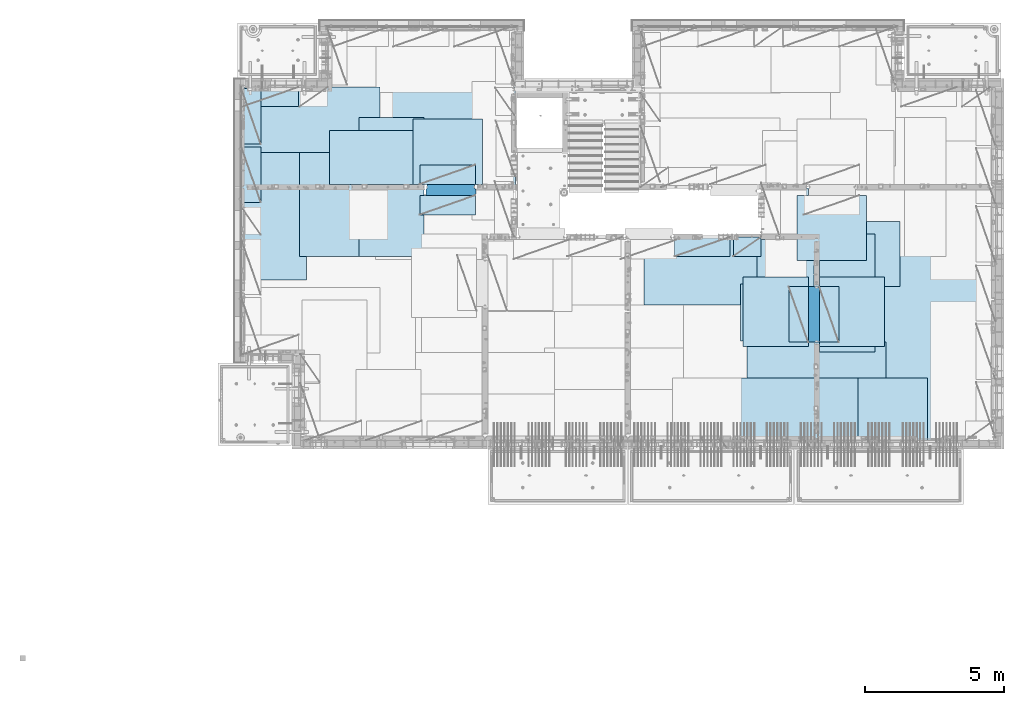
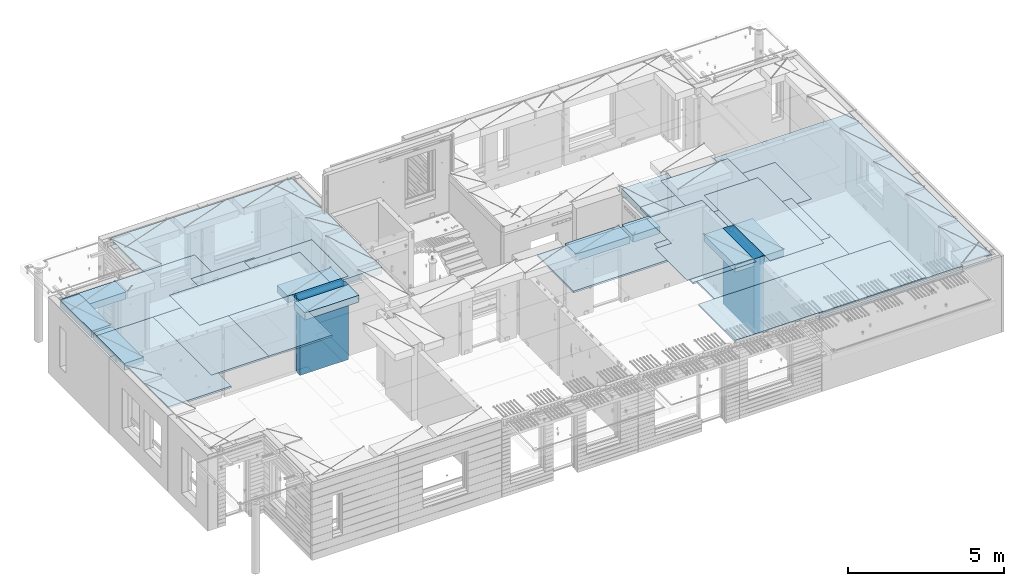
# One storey, part 198 of 341: 27 plates, 2 slabs, 25 elements without a shape of their own.
"""IFC2X3 building model written with IfcOpenShell, lengths in millimetres."""

from ifc_helpers import new_model, si_unit, frame, origin_with_axes, place, context, subcontext, project, spatial, faceted_brep, material, type_object, element, aggregate, save


model = new_model("IFC2X3")

# Units and contexts
model_context = context("Model", 3, precision=1e-05, world=origin_with_axes())
body_context = subcontext(model_context, "Body", "Model", "MODEL_VIEW")
ifc_project = project(units=[si_unit("LENGTHUNIT", "METRE", prefix="MILLI"), si_unit("AREAUNIT", "SQUARE_METRE"), si_unit("VOLUMEUNIT", "CUBIC_METRE"), si_unit("MASSUNIT", "GRAM", prefix="KILO"), si_unit("TIMEUNIT", "SECOND"), si_unit("PLANEANGLEUNIT", "RADIAN"), si_unit("SOLIDANGLEUNIT", "STERADIAN"), si_unit("THERMODYNAMICTEMPERATUREUNIT", "DEGREE_CELSIUS"), si_unit("LUMINOUSINTENSITYUNIT", "LUMEN")], contexts=[model_context])

# Site, building, storey
site_placement = place(None, origin_with_axes())
site = spatial("IfcSite", under=ifc_project, at=site_placement, CompositionType="ELEMENT")
building_placement = place(site_placement, origin_with_axes())
building = spatial("IfcBuilding", under=site, at=building_placement, CompositionType="ELEMENT")
storey_placement = place(building_placement, origin_with_axes())
storey = spatial("IfcBuildingStorey", under=building, at=storey_placement, Name="5", CompositionType="ELEMENT", Elevation=0.0)

# Assembly, slabs
assembly_1_placement = place(storey_placement, origin_with_axes())
assembly_1 = element("IfcElementAssembly", 1, at=assembly_1_placement, inside=storey, AssemblyPlace="NOTDEFINED", PredefinedType="REINFORCEMENT_UNIT")
ifc_material_1 = material(Name="CONCRETE/C30/37")
slab_type_1 = type_object("IfcSlabType", PredefinedType="NOTDEFINED")
slab_1_placement = place(assembly_1_placement, frame((7880.0, 16980.0, 96595.0), z_axis=(0.0, 1.0, 0.0), x_axis=(1.0, 0.0, 0.0)))
slab_1 = element("IfcSlab", 2, at=slab_1_placement, type_object=slab_type_1, material=ifc_material_1, PredefinedType="FLOOR", context=body_context, shape_type="Brep", body=[
    faceted_brep([(6583.68914550781, -135.0, 0.0), (6583.68914550781, 135.0, 0.0), (6583.68914550781, 135.0, 100.0), (6583.68914550781, -135.0, 100.0), (6649.99914550781, -135.0, 99.9997787475586), (6649.99914550781, 135.0, 99.9997787475586), (1.81898940354586e-12, -135.0, 1.81898940354586e-12), (-0.0001220703125, -135.0, 3600.0), (-0.0001220703125, 135.0, 3600.0), (1.81898940354586e-12, 135.0, 1.81898940354586e-12), (3110.00024414063, -135.0, 3600.0), (3110.00024414063, 135.0, 3600.0), (3110.00024414063, -135.0, 5760.0), (3110.00024414063, 135.0, 5760.0), (9850.0009765625, -135.0, 5760.0), (9850.0009765625, 135.0, 5760.0), (9850.0009765625, -135.0, 3600.0), (9850.0009765625, 135.0, 3600.0), (9870.0, -135.0, 3600.0), (9870.0, 135.0, 3600.0), (9870.0, -135.0, 0.0), (9870.0, 135.0, 0.0), (8449.99914550781, -135.0, 0.0), (8449.99914550781, 135.0, 0.0), (8449.99914550781, -135.0, 99.9997787475586), (8449.99914550781, 135.0, 99.9997787475586), (8283.68914550781, -135.0, 99.9997787475586), (8283.68914550781, 135.0, 99.9997787475586)], [[[0, 1, 2, 3]], [[4, 3, 2, 5]], [[6, 7, 8, 9]], [[7, 10, 11, 8]], [[10, 12, 13, 11]], [[12, 14, 15, 13]], [[14, 16, 17, 15]], [[16, 18, 19, 17]], [[18, 20, 21, 19]], [[21, 20, 22, 23]], [[24, 25, 23, 22]], [[26, 4, 5, 27, 25, 24]], [[1, 9, 8, 11, 13, 15, 17, 19, 21, 23, 25, 27, 5, 2]], [[6, 9, 1, 0]], [[26, 24, 22, 20, 18, 16, 14, 12, 10, 7, 6, 0, 3, 4]]]),
])
slab_type_2 = type_object("IfcSlabType", PredefinedType="NOTDEFINED")
slab_2_placement = place(assembly_1_placement, frame((28610.0, 7708.0, 96595.0), z_axis=(0.0, 1.0, 0.0), x_axis=(1.0, 0.0, 0.0)))
slab_2 = element("IfcSlab", 3, at=slab_2_placement, type_object=slab_type_2, material=ifc_material_1, PredefinedType="FLOOR", context=body_context, shape_type="Brep", body=[
    faceted_brep([(0.0, -135.0, 7430.0), (0.0, 135.0, 7430.0), (0.0, 135.0, 5722.0), (0.0, -135.0, 5722.0), (-1999.99938964844, -135.0, 7430.0), (-1999.99938964844, 135.0, 7430.0), (-1999.99938964844, -135.0, 9230.0), (-1999.99938964844, 135.0, 9230.0), (-300.000239723071, -135.0, 9230.0), (-300.000239723071, 135.0, 9230.0), (-300.00008947117, -135.0, 8972.00002930513), (-300.00008947117, 135.0, 8972.00002930513), (1385.00027673977, -135.0, 8972.00002930513), (1400.0006429507, -135.0, 8972.00002930513), (1400.0006429507, 135.0, 8972.00002930513), (1385.00027673977, 135.0, 8972.00002930513), (1400.0006429507, -135.0, 9230.0), (1400.0006429507, 135.0, 9230.0), (6449.99951171875, -135.0, 9230.0), (6449.99951171875, 135.0, 9230.0), (6449.99951171875, -135.0, 100.00023651123), (6449.99951171875, 135.0, 100.00023651123), (5318.0, -135.0, 100.0), (5318.0, 135.0, 100.0), (5318.0, -135.0, -8.68840288603678e-09), (5318.0, 135.0, -8.68840288603678e-09), (1.81898940354586e-12, -135.0, 1.81898940354586e-12), (1.81898940354586e-12, 135.0, 1.81898940354586e-12), (0.0, 135.0, 3679.99963378906), (100.00089263916, 135.0, 3679.99963378906), (100.00089263916, 135.0, 3822.0), (100.00089263916, 135.0, 5679.99963378906), (100.00089263916, 135.0, 5722.0), (100.00089263916, -135.0, 5722.0), (100.00089263916, -135.0, 3822.0), (100.00089263916, -135.0, 3679.99963378906), (0.0, -135.0, 3679.99963378906), (100.00089263916, -135.0, 5679.99963378906)], [[[0, 1, 2, 3]], [[0, 4, 5, 1]], [[4, 6, 7, 5]], [[7, 6, 8, 9]], [[8, 10, 11, 9]], [[12, 13, 14, 15, 11, 10]], [[16, 17, 14, 13]], [[18, 19, 17, 16]], [[18, 20, 21, 19]], [[20, 22, 23, 21]], [[22, 24, 25, 23]], [[24, 26, 27, 25]], [[1, 5, 7, 9, 11, 15, 14, 17, 19, 21, 23, 25, 27, 28, 29, 30, 31, 32, 2]], [[3, 2, 32, 33]], [[34, 35, 36, 26, 24, 22, 20, 18, 16, 13, 12, 10, 8, 6, 4, 0, 3, 33, 37]], [[27, 26, 36, 28]], [[35, 29, 28, 36]], [[34, 37, 31, 30, 29, 35]], [[33, 32, 31, 37]]]),
])

# Assembly, plate
assembly_2_placement = place(storey_placement, origin_with_axes())
assembly_2 = element("IfcElementAssembly", 4, at=assembly_2_placement, inside=storey, Name="Steel Assembly", AssemblyPlace="NOTDEFINED", PredefinedType="NOTDEFINED")
ifc_material_2 = material()
plate_type_1 = type_object("IfcPlateType", PredefinedType="NOTDEFINED")
plate_1_placement = place(assembly_2_placement, frame((27902.5000293051, 16680.0, 96695.1), z_axis=(1.0, 0.0, 0.0), x_axis=(0.0, -1.0, 0.0)))
plate_1 = element("IfcPlate", 5, at=plate_1_placement, type_object=plate_type_1, material=ifc_material_2, Name="1/2", context=body_context, shape_type="Brep", body=[
    faceted_brep([(0.0, -35.0, 0.0), (0.0, -35.0, 2500.0), (0.0, 35.0, 2500.0), (0.0, 35.0, 0.0), (2349.99951171875, -35.0, 2500.0), (2349.99951171875, 35.0, 2500.0), (2350.0, -35.0, 0.0), (2350.0, 35.0, 0.0)], [[[0, 1, 2, 3]], [[1, 4, 5, 2]], [[4, 6, 7, 5]], [[6, 0, 3, 7]], [[5, 7, 3, 2]], [[6, 4, 1, 0]]]),
])
aggregate(assembly_2, [plate_1])

assembly_3_placement = place(storey_placement, origin_with_axes())
assembly_3 = element("IfcElementAssembly", 6, at=assembly_3_placement, inside=storey, Name="Steel Assembly", AssemblyPlace="NOTDEFINED", PredefinedType="NOTDEFINED")
plate_2_placement = place(assembly_3_placement, frame((32610.0, 7750.0, 96695.1), z_axis=(-1.0, 3.00000001838171e-08, 0.0), x_axis=(0.0, 1.0, 0.0)))
plate_2 = element("IfcPlate", 7, at=plate_2_placement, type_object=plate_type_1, material=ifc_material_2, Name="1/2", context=body_context, shape_type="Brep", body=[
    faceted_brep([(0.0, -35.0, 0.0), (0.0, -35.0, 2500.0), (0.0, 35.0, 2500.0), (0.0, 35.0, 0.0), (2349.99951171875, -35.0, 2500.0), (2349.99951171875, 35.0, 2500.0), (2350.0, -35.0, 0.0), (2350.0, 35.0, 0.0)], [[[0, 1, 2, 3]], [[1, 4, 5, 2]], [[4, 6, 7, 5]], [[6, 0, 3, 7]], [[5, 7, 3, 2]], [[6, 4, 1, 0]]]),
])
aggregate(assembly_3, [plate_2])

assembly_4_placement = place(storey_placement, origin_with_axes())
assembly_4 = element("IfcElementAssembly", 8, at=assembly_4_placement, inside=storey, Name="Steel Assembly", AssemblyPlace="NOTDEFINED", PredefinedType="NOTDEFINED")
plate_3_placement = place(assembly_4_placement, frame((27395.0, 12730.0, 96695.1), z_axis=(-1.0, 3.00000001838171e-08, 0.0), x_axis=(0.0, 1.0, 0.0)))
plate_3 = element("IfcPlate", 9, at=plate_3_placement, type_object=plate_type_1, material=ifc_material_2, context=body_context, shape_type="Brep", body=[
    faceted_brep([(0.0, -35.0, 0.0), (0.0, -35.0, 5000.0), (0.0, 35.0, 5000.0), (0.0, 35.0, 0.0), (2349.99951171875, -35.0, 5000.0), (2349.99951171875, 35.0, 5000.0), (2350.0, -35.0, 0.0), (2350.0, 35.0, 0.0)], [[[0, 1, 2, 3]], [[1, 4, 5, 2]], [[4, 6, 7, 5]], [[6, 0, 3, 7]], [[5, 7, 3, 2]], [[6, 4, 1, 0]]]),
])
aggregate(assembly_4, [plate_3])

assembly_5_placement = place(storey_placement, origin_with_axes())
assembly_5 = element("IfcElementAssembly", 10, at=assembly_5_placement, inside=storey, Name="Steel Assembly", AssemblyPlace="NOTDEFINED", PredefinedType="NOTDEFINED")
plate_4_placement = place(assembly_5_placement, frame((28709.9995320312, 11230.0000289158, 96695.1), z_axis=(0.0, 1.0, 0.0), x_axis=(1.0, 0.0, 0.0)))
plate_4 = element("IfcPlate", 11, at=plate_4_placement, type_object=plate_type_1, material=ifc_material_2, Name="1/2", context=body_context, shape_type="Brep", body=[
    faceted_brep([(0.0, -35.0, 0.0), (0.0, -35.0, 2500.0), (0.0, 35.0, 2500.0), (0.0, 35.0, 0.0), (2349.99951171875, -35.0, 2500.0), (2349.99951171875, 35.0, 2500.0), (2350.0, -35.0, 0.0), (2350.0, 35.0, 0.0)], [[[0, 1, 2, 3]], [[1, 4, 5, 2]], [[4, 6, 7, 5]], [[6, 0, 3, 7]], [[5, 7, 3, 2]], [[6, 4, 1, 0]]]),
])
aggregate(assembly_5, [plate_4])

assembly_6_placement = place(storey_placement, origin_with_axes())
assembly_6 = element("IfcElementAssembly", 12, at=assembly_6_placement, inside=storey, Name="Steel Assembly", AssemblyPlace="NOTDEFINED", PredefinedType="NOTDEFINED")
plate_5_placement = place(assembly_6_placement, frame((25959.9995320312, 11230.0000289158, 96695.1), z_axis=(0.0, 1.0, 0.0), x_axis=(1.0, 0.0, 0.0)))
plate_5 = element("IfcPlate", 13, at=plate_5_placement, type_object=plate_type_1, material=ifc_material_2, Name="1/2", context=body_context, shape_type="Brep", body=[
    faceted_brep([(0.0, -35.0, 0.0), (0.0, -35.0, 2500.0), (0.0, 35.0, 2500.0), (0.0, 35.0, 0.0), (2349.99951171875, -35.0, 2500.0), (2349.99951171875, 35.0, 2500.0), (2350.0, -35.0, 0.0), (2350.0, 35.0, 0.0)], [[[0, 1, 2, 3]], [[1, 4, 5, 2]], [[4, 6, 7, 5]], [[6, 0, 3, 7]], [[5, 7, 3, 2]], [[6, 4, 1, 0]]]),
])
aggregate(assembly_6, [plate_5])

assembly_7_placement = place(storey_placement, origin_with_axes())
assembly_7 = element("IfcElementAssembly", 14, at=assembly_7_placement, inside=storey, Name="Steel Assembly", AssemblyPlace="NOTDEFINED", PredefinedType="NOTDEFINED")
plate_6_placement = place(assembly_7_placement, frame((7880.0, 20580.0, 96695.1), z_axis=(1.0, 0.0, 0.0), x_axis=(0.0, -1.0, 0.0)))
plate_6 = element("IfcPlate", 15, at=plate_6_placement, type_object=plate_type_1, material=ifc_material_2, context=body_context, shape_type="Brep", body=[
    faceted_brep([(0.0, -35.0, 0.0), (0.0, -35.0, 5000.0), (0.0, 35.0, 5000.0), (0.0, 35.0, 0.0), (2349.99951171875, -35.0, 5000.0), (2349.99951171875, 35.0, 5000.0), (2350.0, -35.0, 0.0), (2350.0, 35.0, 0.0)], [[[0, 1, 2, 3]], [[1, 4, 5, 2]], [[4, 6, 7, 5]], [[6, 0, 3, 7]], [[5, 7, 3, 2]], [[6, 4, 1, 0]]]),
])
aggregate(assembly_7, [plate_6])

assembly_8_placement = place(storey_placement, origin_with_axes())
assembly_8 = element("IfcElementAssembly", 16, at=assembly_8_placement, inside=storey, Name="Steel Assembly", AssemblyPlace="NOTDEFINED", PredefinedType="NOTDEFINED")
plate_7_placement = place(assembly_8_placement, frame((14063.69, 19430.0, 96695.1), z_axis=(1.0, 0.0, 0.0), x_axis=(0.0, -1.0, 0.0)))
plate_7 = element("IfcPlate", 17, at=plate_7_placement, type_object=plate_type_1, material=ifc_material_2, Name="1/2", context=body_context, shape_type="Brep", body=[
    faceted_brep([(0.0, -35.0, 0.0), (0.0, -35.0, 2500.0), (0.0, 35.0, 2500.0), (0.0, 35.0, 0.0), (2349.99951171875, -35.0, 2500.0), (2349.99951171875, 35.0, 2500.0), (2350.0, -35.0, 0.0), (2350.0, 35.0, 0.0)], [[[0, 1, 2, 3]], [[1, 4, 5, 2]], [[4, 6, 7, 5]], [[6, 0, 3, 7]], [[5, 7, 3, 2]], [[6, 4, 1, 0]]]),
])
aggregate(assembly_8, [plate_7])

assembly_9_placement = place(storey_placement, origin_with_axes())
assembly_9 = element("IfcElementAssembly", 18, at=assembly_9_placement, inside=storey, Name="Steel Assembly", AssemblyPlace="NOTDEFINED", PredefinedType="NOTDEFINED")
plate_8_placement = place(assembly_9_placement, frame((31610.0, 13388.0, 96695.1), z_axis=(-1.0, 3.00000001838171e-08, 0.0), x_axis=(0.0, 1.0, 0.0)))
plate_8 = element("IfcPlate", 19, at=plate_8_placement, type_object=plate_type_1, material=ifc_material_2, context=body_context, shape_type="Brep", body=[
    faceted_brep([(0.0, -35.0, 0.0), (0.0, -35.0, 5000.0), (0.0, 35.0, 5000.0), (0.0, 35.0, 0.0), (2349.99951171875, -35.0, 5000.0), (2349.99951171875, 35.0, 5000.0), (2350.0, -35.0, 0.0), (2350.0, 35.0, 0.0)], [[[0, 1, 2, 3]], [[1, 4, 5, 2]], [[4, 6, 7, 5]], [[6, 0, 3, 7]], [[5, 7, 3, 2]], [[6, 4, 1, 0]]]),
])
aggregate(assembly_9, [plate_8])

assembly_10_placement = place(storey_placement, origin_with_axes())
assembly_10 = element("IfcElementAssembly", 20, at=assembly_10_placement, inside=storey, Name="Steel Assembly", AssemblyPlace="NOTDEFINED", PredefinedType="NOTDEFINED")
plate_9_placement = place(assembly_10_placement, frame((31110.0, 9038.0, 96695.1), z_axis=(-1.0, 3.00000001838171e-08, 0.0), x_axis=(0.0, 1.0, 0.0)))
plate_9 = element("IfcPlate", 21, at=plate_9_placement, type_object=plate_type_1, material=ifc_material_2, context=body_context, shape_type="Brep", body=[
    faceted_brep([(0.0, -35.0, 0.0), (0.0, -35.0, 5000.0), (0.0, 35.0, 5000.0), (0.0, 35.0, 0.0), (2349.99951171875, -35.0, 5000.0), (2349.99951171875, 35.0, 5000.0), (2350.0, -35.0, 0.0), (2350.0, 35.0, 0.0)], [[[0, 1, 2, 3]], [[1, 4, 5, 2]], [[4, 6, 7, 5]], [[6, 0, 3, 7]], [[5, 7, 3, 2]], [[6, 4, 1, 0]]]),
])
aggregate(assembly_10, [plate_9])

assembly_11_placement = place(storey_placement, origin_with_axes())
assembly_11 = element("IfcElementAssembly", 22, at=assembly_11_placement, inside=storey, Name="Steel Assembly", AssemblyPlace="NOTDEFINED", PredefinedType="NOTDEFINED")
plate_10_placement = place(assembly_11_placement, frame((30510.0, 7750.0, 96695.1), z_axis=(-1.0, 3.00000001838171e-08, 0.0), x_axis=(0.0, 1.0, 0.0)))
plate_10 = element("IfcPlate", 23, at=plate_10_placement, type_object=plate_type_1, material=ifc_material_2, context=body_context, shape_type="Brep", body=[
    faceted_brep([(0.0, -35.0, 0.0), (0.0, -35.0, 5000.0), (0.0, 35.0, 5000.0), (0.0, 35.0, 0.0), (2349.99951171875, -35.0, 5000.0), (2349.99951171875, 35.0, 5000.0), (2350.0, -35.0, 0.0), (2350.0, 35.0, 0.0)], [[[0, 1, 2, 3]], [[1, 4, 5, 2]], [[4, 6, 7, 5]], [[6, 0, 3, 7]], [[5, 7, 3, 2]], [[6, 4, 1, 0]]]),
])
aggregate(assembly_11, [plate_10])

assembly_12_placement = place(storey_placement, origin_with_axes())
assembly_12 = element("IfcElementAssembly", 24, at=assembly_12_placement, inside=storey, Name="Steel Assembly", AssemblyPlace="NOTDEFINED", PredefinedType="NOTDEFINED")
plate_11_placement = place(assembly_12_placement, frame((10230.0, 18627.0, 96695.1), z_axis=(0.0, -1.0, 0.0), x_axis=(-1.0, 3.00000001838171e-08, 0.0)))
plate_11 = element("IfcPlate", 25, at=plate_11_placement, type_object=plate_type_1, material=ifc_material_2, context=body_context, shape_type="Brep", body=[
    faceted_brep([(0.0, -35.0, 0.0), (0.0, -35.0, 5000.0), (0.0, 35.0, 5000.0), (0.0, 35.0, 0.0), (2349.99951171875, -35.0, 5000.0), (2349.99951171875, 35.0, 5000.0), (2350.0, -35.0, 0.0), (2350.0, 35.0, 0.0)], [[[0, 1, 2, 3]], [[1, 4, 5, 2]], [[4, 6, 7, 5]], [[6, 0, 3, 7]], [[5, 7, 3, 2]], [[6, 4, 1, 0]]]),
])
aggregate(assembly_12, [plate_11])

assembly_13_placement = place(storey_placement, origin_with_axes())
assembly_13 = element("IfcElementAssembly", 26, at=assembly_13_placement, inside=storey, Name="Steel Assembly", AssemblyPlace="NOTDEFINED", PredefinedType="NOTDEFINED")
plate_12_placement = place(assembly_13_placement, frame((14463.69, 19480.0, 96695.1), z_axis=(0.0, -1.0, 0.0), x_axis=(-1.0, 3.00000001838171e-08, 0.0)))
plate_12 = element("IfcPlate", 27, at=plate_12_placement, type_object=plate_type_1, material=ifc_material_2, context=body_context, shape_type="Brep", body=[
    faceted_brep([(0.0, -35.0, 0.0), (0.0, -35.0, 5000.0), (0.0, 35.0, 5000.0), (0.0, 35.0, 0.0), (2349.99951171875, -35.0, 5000.0), (2349.99951171875, 35.0, 5000.0), (2350.0, -35.0, 0.0), (2350.0, 35.0, 0.0)], [[[0, 1, 2, 3]], [[1, 4, 5, 2]], [[4, 6, 7, 5]], [[6, 0, 3, 7]], [[5, 7, 3, 2]], [[6, 4, 1, 0]]]),
])
aggregate(assembly_13, [plate_12])

assembly_14_placement = place(storey_placement, origin_with_axes())
assembly_14 = element("IfcElementAssembly", 28, at=assembly_14_placement, inside=storey, Name="Steel Assembly", AssemblyPlace="NOTDEFINED", PredefinedType="NOTDEFINED")
plate_13_placement = place(assembly_14_placement, frame((12330.0, 19480.0, 96695.1), z_axis=(0.0, -1.0, 0.0), x_axis=(-1.0, 3.00000001838171e-08, 0.0)))
plate_13 = element("IfcPlate", 29, at=plate_13_placement, type_object=plate_type_1, material=ifc_material_2, context=body_context, shape_type="Brep", body=[
    faceted_brep([(0.0, -35.0, 0.0), (0.0, -35.0, 5000.0), (0.0, 35.0, 5000.0), (0.0, 35.0, 0.0), (2349.99951171875, -35.0, 5000.0), (2349.99951171875, 35.0, 5000.0), (2350.0, -35.0, 0.0), (2350.0, 35.0, 0.0)], [[[0, 1, 2, 3]], [[1, 4, 5, 2]], [[4, 6, 7, 5]], [[6, 0, 3, 7]], [[5, 7, 3, 2]], [[6, 4, 1, 0]]]),
])
aggregate(assembly_14, [plate_13])

assembly_15_placement = place(storey_placement, origin_with_axes())
assembly_15 = element("IfcElementAssembly", 30, at=assembly_15_placement, inside=storey, Name="Steel Assembly", AssemblyPlace="NOTDEFINED", PredefinedType="NOTDEFINED")
plate_type_2 = type_object("IfcPlateType", PredefinedType="NOTDEFINED")
plate_14_placement = place(assembly_15_placement, frame((7879.99987792969, 20530.0, 96595.3), z_axis=(1.0, 0.0, 0.0), x_axis=(0.0, -1.0, 0.0)))
plate_14 = element("IfcPlate", 31, at=plate_14_placement, type_object=plate_type_2, material=ifc_material_2, Name="RE1", context=body_context, shape_type="Brep", body=[
    faceted_brep([(1.81898940354586e-12, -135.0, 1.81898940354586e-12), (0.0, -135.0, 699.999999999996), (0.0, 135.0, 699.999999999996), (1.81898940354586e-12, 135.0, 1.81898940354586e-12), (1999.99951171875, -135.0, 699.999999999993), (1999.99951171875, 135.0, 699.999999999993), (2000.0, -135.0, -3.63797880709171e-12), (2000.0, 135.0, -3.63797880709171e-12)], [[[0, 1, 2, 3]], [[1, 4, 5, 2]], [[4, 6, 7, 5]], [[6, 0, 3, 7]], [[5, 7, 3, 2]], [[6, 4, 1, 0]]]),
])
aggregate(assembly_15, [plate_14])

assembly_16_placement = place(storey_placement, origin_with_axes())
assembly_16 = element("IfcElementAssembly", 32, at=assembly_16_placement, inside=storey, Name="Steel Assembly", AssemblyPlace="NOTDEFINED", PredefinedType="NOTDEFINED")
plate_15_placement = place(assembly_16_placement, frame((28710.2298779297, 13388.0, 96595.3), z_axis=(1.0, 0.0, 0.0), x_axis=(0.0, -1.0, 0.0)))
plate_15 = element("IfcPlate", 33, at=plate_15_placement, type_object=plate_type_2, material=ifc_material_2, Name="RE1", context=body_context, shape_type="Brep", body=[
    faceted_brep([(1.81898940354586e-12, -135.0, 1.81898940354586e-12), (0.0, -135.0, 699.999999999996), (0.0, 135.0, 699.999999999996), (1.81898940354586e-12, 135.0, 1.81898940354586e-12), (1999.99951171875, -135.0, 699.999999999993), (1999.99951171875, 135.0, 699.999999999993), (2000.0, -135.0, -3.63797880709171e-12), (2000.0, 135.0, -3.63797880709171e-12)], [[[0, 1, 2, 3]], [[1, 4, 5, 2]], [[4, 6, 7, 5]], [[6, 0, 3, 7]], [[5, 7, 3, 2]], [[6, 4, 1, 0]]]),
])
aggregate(assembly_16, [plate_15])

assembly_17_placement = place(storey_placement, origin_with_axes())
assembly_17 = element("IfcElementAssembly", 34, at=assembly_17_placement, inside=storey, Name="Steel Assembly", AssemblyPlace="NOTDEFINED", PredefinedType="NOTDEFINED")
plate_16_placement = place(assembly_17_placement, frame((28310.0001220703, 11388.0, 96595.3), z_axis=(-1.0, 3.00000001838171e-08, 0.0), x_axis=(0.0, 1.0, 0.0)))
plate_16 = element("IfcPlate", 35, at=plate_16_placement, type_object=plate_type_2, material=ifc_material_2, Name="RE1", context=body_context, shape_type="Brep", body=[
    faceted_brep([(1.81898940354586e-12, -135.0, 1.81898940354586e-12), (0.0, -135.0, 699.999999999996), (0.0, 135.0, 699.999999999996), (1.81898940354586e-12, 135.0, 1.81898940354586e-12), (1999.99951171875, -135.0, 699.999999999993), (1999.99951171875, 135.0, 699.999999999993), (2000.0, -135.0, -3.63797880709171e-12), (2000.0, 135.0, -3.63797880709171e-12)], [[[0, 1, 2, 3]], [[1, 4, 5, 2]], [[4, 6, 7, 5]], [[6, 0, 3, 7]], [[5, 7, 3, 2]], [[6, 4, 1, 0]]]),
])
aggregate(assembly_17, [plate_16])

assembly_18_placement = place(storey_placement, origin_with_axes())
assembly_18 = element("IfcElementAssembly", 36, at=assembly_18_placement, inside=storey, Name="Steel Assembly", AssemblyPlace="NOTDEFINED", PredefinedType="NOTDEFINED")
plate_17_placement = place(assembly_18_placement, frame((14313.6908542386, 17080.0001036336, 96595.3), z_axis=(0.0, 1.0, 0.0), x_axis=(1.0, 0.0, 0.0)))
plate_17 = element("IfcPlate", 37, at=plate_17_placement, type_object=plate_type_2, material=ifc_material_2, Name="RE1", context=body_context, shape_type="Brep", body=[
    faceted_brep([(1.81898940354586e-12, -135.0, 1.81898940354586e-12), (0.0, -135.0, 699.999999999996), (0.0, 135.0, 699.999999999996), (1.81898940354586e-12, 135.0, 1.81898940354586e-12), (1999.99951171875, -135.0, 699.999999999993), (1999.99951171875, 135.0, 699.999999999993), (2000.0, -135.0, -3.63797880709171e-12), (2000.0, 135.0, -3.63797880709171e-12)], [[[0, 1, 2, 3]], [[1, 4, 5, 2]], [[4, 6, 7, 5]], [[6, 0, 3, 7]], [[5, 7, 3, 2]], [[6, 4, 1, 0]]]),
])
aggregate(assembly_18, [plate_17])

assembly_19_placement = place(storey_placement, origin_with_axes())
assembly_19 = element("IfcElementAssembly", 38, at=assembly_19_placement, inside=storey, Name="Steel Assembly", AssemblyPlace="NOTDEFINED", PredefinedType="NOTDEFINED")
plate_18_placement = place(assembly_19_placement, frame((16313.6891457614, 16679.9998963664, 96595.3), z_axis=(0.0, -1.0, 0.0), x_axis=(-1.0, 3.00000001838171e-08, 0.0)))
plate_18 = element("IfcPlate", 39, at=plate_18_placement, type_object=plate_type_2, material=ifc_material_2, Name="RE1", context=body_context, shape_type="Brep", body=[
    faceted_brep([(1.81898940354586e-12, -135.0, 1.81898940354586e-12), (0.0, -135.0, 699.999999999996), (0.0, 135.0, 699.999999999996), (1.81898940354586e-12, 135.0, 1.81898940354586e-12), (1999.99951171875, -135.0, 699.999999999993), (1999.99951171875, 135.0, 699.999999999993), (2000.0, -135.0, -3.63797880709171e-12), (2000.0, 135.0, -3.63797880709171e-12)], [[[0, 1, 2, 3]], [[1, 4, 5, 2]], [[4, 6, 7, 5]], [[6, 0, 3, 7]], [[5, 7, 3, 2]], [[6, 4, 1, 0]]]),
])
aggregate(assembly_19, [plate_18])

assembly_20_placement = place(storey_placement, origin_with_axes())
assembly_20 = element("IfcElementAssembly", 40, at=assembly_20_placement, inside=storey, Name="Steel Assembly", AssemblyPlace="NOTDEFINED", PredefinedType="NOTDEFINED")
plate_19_placement = place(assembly_20_placement, frame((25494.9991457614, 15179.9998963664, 96595.3), z_axis=(0.0, -1.0, 0.0), x_axis=(-1.0, 3.00000001838171e-08, 0.0)))
plate_19 = element("IfcPlate", 41, at=plate_19_placement, type_object=plate_type_2, material=ifc_material_2, Name="RE1", context=body_context, shape_type="Brep", body=[
    faceted_brep([(1.81898940354586e-12, -135.0, 1.81898940354586e-12), (0.0, -135.0, 699.999999999996), (0.0, 135.0, 699.999999999996), (1.81898940354586e-12, 135.0, 1.81898940354586e-12), (1999.99951171875, -135.0, 699.999999999993), (1999.99951171875, 135.0, 699.999999999993), (2000.0, -135.0, -3.63797880709171e-12), (2000.0, 135.0, -3.63797880709171e-12)], [[[0, 1, 2, 3]], [[1, 4, 5, 2]], [[4, 6, 7, 5]], [[6, 0, 3, 7]], [[5, 7, 3, 2]], [[6, 4, 1, 0]]]),
])
aggregate(assembly_20, [plate_19])

assembly_21_placement = place(storey_placement, origin_with_axes())
assembly_21 = element("IfcElementAssembly", 42, at=assembly_21_placement, inside=storey, Name="Steel Assembly", AssemblyPlace="NOTDEFINED", PredefinedType="NOTDEFINED")
plate_20_placement = place(assembly_21_placement, frame((26610.0, 15180.0000000707, 96595.3), z_axis=(0.0, -1.0, 0.0), x_axis=(-1.0, 3.00000001838171e-08, 0.0)))
plate_20 = element("IfcPlate", 43, at=plate_20_placement, type_object=plate_type_2, material=ifc_material_2, Name="RE1_1/2", context=body_context, shape_type="Brep", body=[
    faceted_brep([(1.81898940354586e-12, -135.0, 1.81898940354586e-12), (0.0, -135.0, 699.999999999996), (0.0, 135.0, 699.999999999996), (1.81898940354586e-12, 135.0, 1.81898940354586e-12), (999.99951171875, -135.0, 700.0), (999.99951171875, 135.0, 700.0), (1000.0, -135.0, 0.0), (1000.0, 135.0, 0.0)], [[[0, 1, 2, 3]], [[1, 4, 5, 2]], [[4, 6, 7, 5]], [[6, 0, 3, 7]], [[5, 7, 3, 2]], [[6, 4, 1, 0]]]),
])
aggregate(assembly_21, [plate_20])

assembly_22_placement = place(storey_placement, origin_with_axes())
assembly_22 = element("IfcElementAssembly", 44, at=assembly_22_placement, inside=storey, Name="Steel Assembly", AssemblyPlace="NOTDEFINED", PredefinedType="NOTDEFINED")
plate_21_placement = place(assembly_22_placement, frame((9935.0, 20580.0001220703, 96595.3), z_axis=(0.0, -1.0, 0.0), x_axis=(-1.0, 3.00000001838171e-08, 0.0)))
plate_21 = element("IfcPlate", 45, at=plate_21_placement, type_object=plate_type_2, material=ifc_material_2, Name="RE1", context=body_context, shape_type="Brep", body=[
    faceted_brep([(1.81898940354586e-12, -135.0, 1.81898940354586e-12), (0.0, -135.0, 699.999999999996), (0.0, 135.0, 699.999999999996), (1.81898940354586e-12, 135.0, 1.81898940354586e-12), (1999.99951171875, -135.0, 699.999999999993), (1999.99951171875, 135.0, 699.999999999993), (2000.0, -135.0, -3.63797880709171e-12), (2000.0, 135.0, -3.63797880709171e-12)], [[[0, 1, 2, 3]], [[1, 4, 5, 2]], [[4, 6, 7, 5]], [[6, 0, 3, 7]], [[5, 7, 3, 2]], [[6, 4, 1, 0]]]),
])
aggregate(assembly_22, [plate_21])

assembly_23_placement = place(storey_placement, origin_with_axes())
assembly_23 = element("IfcElementAssembly", 46, at=assembly_23_placement, inside=storey, Name="Steel Assembly", AssemblyPlace="NOTDEFINED", PredefinedType="NOTDEFINED")
plate_22_placement = place(assembly_23_placement, frame((7879.99987792969, 18430.0, 96595.3), z_axis=(1.0, 0.0, 0.0), x_axis=(0.0, -1.0, 0.0)))
plate_22 = element("IfcPlate", 47, at=plate_22_placement, type_object=plate_type_2, material=ifc_material_2, Name="RE1", context=body_context, shape_type="Brep", body=[
    faceted_brep([(1.81898940354586e-12, -135.0, 1.81898940354586e-12), (0.0, -135.0, 699.999999999996), (0.0, 135.0, 699.999999999996), (1.81898940354586e-12, 135.0, 1.81898940354586e-12), (1999.99951171875, -135.0, 699.999999999993), (1999.99951171875, 135.0, 699.999999999993), (2000.0, -135.0, -3.63797880709171e-12), (2000.0, 135.0, -3.63797880709171e-12)], [[[0, 1, 2, 3]], [[1, 4, 5, 2]], [[4, 6, 7, 5]], [[6, 0, 3, 7]], [[5, 7, 3, 2]], [[6, 4, 1, 0]]]),
])
aggregate(assembly_23, [plate_22])

# Plate
plate_type_3 = type_object("IfcPlateType", PredefinedType="NOTDEFINED")
plate_23_placement = place(assembly_1_placement, frame((11048.0003525539, 17079.9997757405, 96725.45), z_axis=(0.0, 1.0, 0.0), x_axis=(1.0, 0.0, 0.0)))
plate_23 = element("IfcPlate", 48, at=plate_23_placement, type_object=plate_type_3, material=ifc_material_2, context=body_context, shape_type="Brep", body=[
    faceted_brep([(0.0, -5.0, 0.0), (0.0, -5.0, 1939.99963378906), (0.0, 5.0, 1939.99963378906), (0.0, 5.0, 0.0), (4827.9990234375, -5.0, 1939.99963378906), (4827.9990234375, 5.0, 1939.99963378906), (4827.9990234375, -5.0, 0.0), (4827.9990234375, 5.0, 0.0)], [[[0, 1, 2, 3]], [[1, 4, 5, 2]], [[4, 6, 7, 5]], [[6, 0, 3, 7]], [[5, 7, 3, 2]], [[6, 4, 1, 0]]]),
])

plate_type_4 = type_object("IfcPlateType", PredefinedType="NOTDEFINED")
plate_24_placement = place(assembly_1_placement, frame((28710.0010086818, 11039.9998138874, 96725.45), z_axis=(0.0, 1.0, 0.0), x_axis=(1.0, 0.0, 0.0)))
plate_24 = element("IfcPlate", 49, at=plate_24_placement, type_object=plate_type_4, material=ifc_material_2, context=body_context, shape_type="Brep", body=[
    faceted_brep([(0.0, -5.0, 0.0), (-0.00100868183653802, -5.0, 4240.0), (-0.00100868183653802, 5.0, 4240.0), (0.0, 5.0, 0.0), (2000.0, -5.0, 4240.0), (2000.0, 5.0, 4240.0), (2000.0, -5.0, 0.0), (2000.0, 5.0, 0.0)], [[[0, 1, 2, 3]], [[1, 4, 5, 2]], [[4, 6, 7, 5]], [[6, 0, 3, 7]], [[5, 7, 3, 2]], [[6, 4, 1, 0]]]),
])

plate_type_5 = type_object("IfcPlateType", PredefinedType="NOTDEFINED")
plate_25_placement = place(assembly_1_placement, frame((25860.0006272121, 11525.9998749226, 96725.45), z_axis=(1.0, 0.0, 0.0), x_axis=(0.0, -1.0, 0.0)))
plate_25 = element("IfcPlate", 50, at=plate_25_placement, type_object=plate_type_5, material=ifc_material_2, context=body_context, shape_type="Brep", body=[
    faceted_brep([(92.0000076293945, -5.0, 2449.99937278789), (92.0000076293945, 5.0, 2449.99937278789), (-1861.99975886647, 5.0, 2449.99937278789), (-1861.99975886647, -5.0, 2449.99937278789), (-1861.99975886647, -5.0, 2649.99937278789), (-1861.99975886647, 5.0, 2649.99939842034), (92.0000076293945, -5.0, 0.0), (0.0, -5.0, 0.0), (0.0, 5.0, 0.0), (92.0000076293945, 5.0, 0.0), (-1954.00048828125, -5.0, 0.0), (-1954.00048828125, 5.0, 0.0), (-1954.00048828125, -5.0, 600.000366210938), (-1954.00048828125, 5.0, 600.000366210938), (-3554.0, -5.0, 600.000366210938), (-3554.0, 5.0, 600.000366210938), (-3554.0, -5.0, 2649.99951171875), (-3554.0, 5.0, 2649.99951171875)], [[[0, 1, 2, 3]], [[4, 3, 2, 5]], [[6, 7, 8, 9]], [[7, 10, 11, 8]], [[10, 12, 13, 11]], [[12, 14, 15, 13]], [[14, 16, 17, 15]], [[17, 16, 4, 5]], [[1, 9, 8, 11, 13, 15, 17, 5, 2]], [[6, 9, 1, 0]], [[16, 14, 12, 10, 7, 6, 0, 3, 4]]]),
])

aggregate(assembly_1, [plate_24, plate_25, plate_23, slab_2, slab_1])

# Assembly, plate
assembly_24_placement = place(storey_placement, origin_with_axes())
assembly_24 = element("IfcElementAssembly", 51, at=assembly_24_placement, inside=storey, Name="Steel Assembly", AssemblyPlace="NOTDEFINED", PredefinedType="NOTDEFINED")
ifc_material_3 = material()
plate_type_6 = type_object("IfcPlateType", PredefinedType="NOTDEFINED")
plate_26_placement = place(assembly_24_placement, frame((14530.0, 16680.0, 95255.6000003815), z_axis=(0.0, 1.0, 0.0), x_axis=(1.0, 0.0, 0.0)))
plate_26 = element("IfcPlate", 52, at=plate_26_placement, type_object=plate_type_6, material=ifc_material_3, context=body_context, shape_type="Brep", body=[
    faceted_brep([(1749.99914550781, -1475.0, 400.0), (1749.99914550781, -1475.0, 243.000000000004), (1749.99914550781, 1475.0, 243.000000000004), (1749.99914550781, 1475.0, 400.0), (1799.99914550781, -1475.0, 221.333333333332), (1799.99914550781, 1475.0, 221.333333333332), (30.0, -1475.0, 400.0), (30.0, 1475.0, 400.0), (30.0, 1475.0, 243.0), (30.0, -1475.0, 243.0), (0.0, 1475.0, 230.0), (0.0, -1475.0, 230.0), (0.0, 1475.0, 0.0), (0.0, -1475.0, 0.0), (1799.99914550781, -1475.0, 3.63797880709171e-12), (1799.99914550781, 1475.0, 3.63797880709171e-12)], [[[0, 1, 2, 3]], [[4, 5, 2, 1]], [[6, 7, 8, 9]], [[9, 8, 10, 11]], [[12, 13, 11, 10]], [[14, 13, 12, 15]], [[0, 6, 9, 11, 13, 14, 4, 1]], [[7, 6, 0, 3]], [[15, 12, 10, 8, 7, 3, 2, 5]], [[14, 15, 5, 4]]]),
])
aggregate(assembly_24, [plate_26])

assembly_25_placement = place(storey_placement, origin_with_axes())
assembly_25 = element("IfcElementAssembly", 53, at=assembly_25_placement, inside=storey, Name="Steel Assembly", AssemblyPlace="NOTDEFINED", PredefinedType="NOTDEFINED")
plate_27_placement = place(assembly_25_placement, frame((28710.0, 11388.0, 95255.6000003815), z_axis=(-1.0, 3.00000001838171e-08, 0.0), x_axis=(0.0, 1.0, 0.0)))
plate_27 = element("IfcPlate", 54, at=plate_27_placement, type_object=plate_type_6, material=ifc_material_3, context=body_context, shape_type="Brep", body=[
    faceted_brep([(0.0, -1475.0, 170.000000230655), (0.0, 1475.0, 170.000000368096), (30.0, 1475.0, 156.999999999998), (30.0, -1475.0, 156.999999999998), (29.9999998430139, -1475.0, 0.0), (29.9999998430139, 1475.0, 0.0), (0.0, -1475.0, 400.0), (1999.99963378906, -1475.0, 400.0), (1999.99963378906, 1475.0, 400.0), (0.0, 1475.0, 400.0), (1999.99963378906, -1475.0, 170.000003831468), (1999.99963378906, 1475.0, 170.000003831468), (1969.99962494722, -1475.0, 157.0), (1969.99962494722, 1475.0, 157.0), (1969.99962494722, -1475.0, 0.0), (1969.99962494722, 1475.0, 0.0)], [[[0, 1, 2, 3]], [[4, 3, 2, 5]], [[6, 7, 8, 9]], [[8, 7, 10, 11]], [[12, 13, 11, 10]], [[14, 15, 13, 12]], [[15, 14, 4, 5]], [[1, 9, 8, 11, 13, 15, 5, 2]], [[6, 9, 1, 0]], [[14, 12, 10, 7, 6, 0, 3, 4]]]),
])
aggregate(assembly_25, [plate_27])

save(model, "model.ifc")
